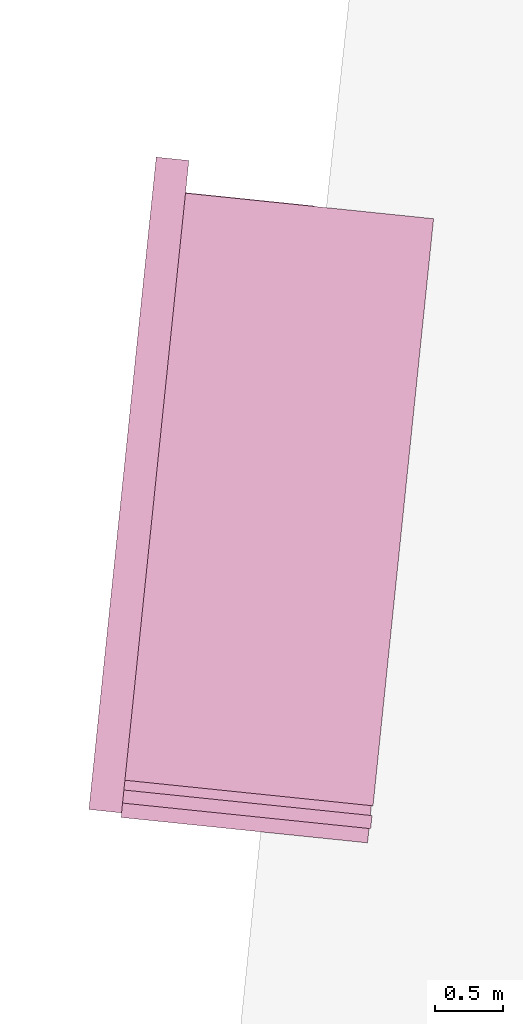
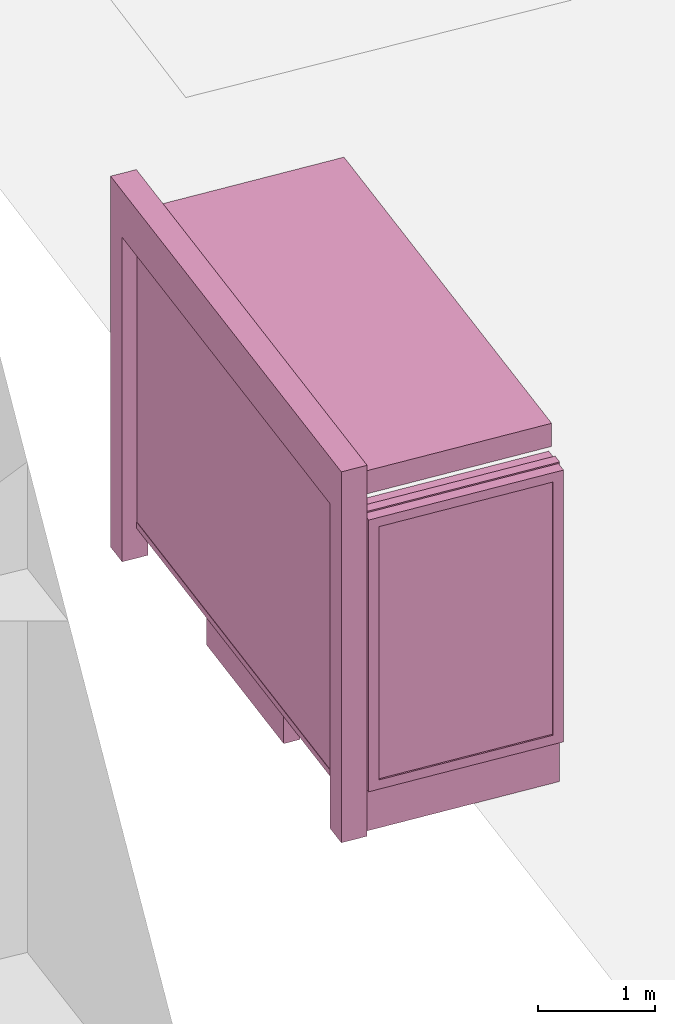
# One storey, part 28 of 200: 1 furnishing.
"""IFC4 building model written with IfcOpenShell, lengths in metres."""

from ifc_helpers import new_model, si_unit, origin_with_axes, place, context, subcontext, project, spatial, triangles, material, element, save


model = new_model("IFC4")

# Units and contexts
model_context = context("Model", 3, precision=1e-05, world=origin_with_axes())
body_context = subcontext(model_context, "Body", "Model", "MODEL_VIEW")
ifc_project = project(units=[si_unit("VOLUMEUNIT", "CUBIC_METRE"), si_unit("LENGTHUNIT", "METRE"), si_unit("AREAUNIT", "SQUARE_METRE")], contexts=[model_context])

# Site, building, storey
site_placement = place(None, origin_with_axes())
site = spatial("IfcSite", under=ifc_project, at=site_placement)
building_placement = place(site_placement, origin_with_axes())
building = spatial("IfcBuilding", under=site, at=building_placement, Name="Building")
storey_placement = place(building_placement, origin_with_axes())
storey = spatial("IfcBuildingStorey", under=building, at=storey_placement, Name="Ground")

# Furnishing
ifc_material = material(Name="busStop")
furnishing_placement = place(storey_placement, origin_with_axes())
element("IfcFurnishingElement", 1, at=furnishing_placement, inside=storey, material=ifc_material, Name="cw_instances_busStop_32", context=body_context, shape_type="Tessellation", body=[
    triangles([(364.8300022669944, -634.9630978992647, 3.3826375611235573), (363.211764228996, -630.4343599842039, 3.3826375611235573), (362.7664539243932, -634.7501776838506, 3.3826375611235573), (365.27531279753816, -630.6472800452291, 3.3826375611235573), (364.8300023629015, -634.9630979091604, 3.6236783199298275), (363.2117643249031, -630.4343599940996, 3.6236783199298275), (365.27531289344523, -630.6472800551248, 3.6236783199298275), (362.7664540203003, -634.7501776937463, 3.6236783199298275), (364.8300022669944, -634.9630978992647, 3.3826375611235573), (365.27531289344523, -630.6472800551248, 3.6236783199298275), (365.27531279753816, -630.6472800452291, 3.3826375611235573), (364.8300023629015, -634.9630979091604, 3.6236783199298275), (365.27531279753816, -630.6472800452291, 3.3826375611235573), (363.2117643249031, -630.4343599940996, 3.6236783199298275), (363.211764228996, -630.4343599842039, 3.3826375611235573), (365.27531289344523, -630.6472800551248, 3.6236783199298275), (363.211764228996, -630.4343599842039, 3.3826375611235573), (362.7664540203003, -634.7501776937463, 3.6236783199298275), (362.7664539243932, -634.7501776838506, 3.3826375611235573), (363.2117643249031, -630.4343599940996, 3.6236783199298275), (362.7664539243932, -634.7501776838506, 3.3826375611235573), (364.8300023629015, -634.9630979091604, 3.6236783199298275), (364.8300022669944, -634.9630978992647, 3.3826375611235573), (362.7664540203003, -634.7501776937463, 3.6236783199298275), (363.00622201757756, -634.774917137996, 3.864718677001767), (362.7417149618365, -634.9899455531278, 3.864718677001767), (362.766454387944, -634.7501777316801, 3.864718677001767), (362.9814825914701, -635.0146849594437, 3.864718677001767), (363.00622201757756, -634.774917137996, 3.6236783199298275), (362.9814825914701, -635.0146849594437, 3.864718677001767), (363.00622201757756, -634.774917137996, 3.864718677001767), (362.9814825914701, -635.0146849594437, 3.6236783199298275), (363.4762719346457, -630.2193318461411, 3.6236783199298275), (363.236504113198, -630.1945924200336, 3.864718677001767), (363.236504113198, -630.1945924200336, 3.6236783199298275), (363.4762719346457, -630.2193318461411, 3.864718677001767), (363.21176470853135, -630.4343600336827, 3.6236783199298275), (363.236504113198, -630.1945924200336, 3.864718677001767), (363.21176470853135, -630.4343600336827, 3.864718677001767), (363.236504113198, -630.1945924200336, 3.6236783199298275), (362.7417147860069, -634.9899455349855, 3.6236783199298275), (362.9814825914701, -635.0146849594437, 3.864718677001767), (362.9814825914701, -635.0146849594437, 3.6236783199298275), (362.7417149618365, -634.9899455531278, 3.864718677001767), (363.4515323381649, -630.4590994399986, 3.864718677001767), (363.21176470853135, -630.4343600336827, 3.864718677001767), (363.4515323381649, -630.4590994399986, 3.6236783199298275), (363.4515323381649, -630.4590994399986, 3.864718677001767), (362.7417147860069, -634.9899455349855, 3.6236783199298275), (362.766454387944, -634.7501777316801, 3.864718677001767), (362.7417149618365, -634.9899455531278, 3.864718677001767), (362.766454387944, -634.7501777316801, 3.6236783199298275), (363.4762719346457, -630.2193318461411, 3.864718677001767), (363.236504113198, -630.1945924200336, 3.864718677001767), (363.4762719346457, -630.2193318461411, 3.6236783199298275), (363.4762719346457, -630.2193318461411, 3.864718677001767), (362.74171392284336, -634.9899454459237, 9.480930192426488e-07), (362.98148145656984, -635.0146848423439, 8.998848996201414e-07), (362.7664533489508, -634.7501776244759, 9.480930192426488e-07), (362.74171392284336, -634.9899454459237, 9.480930192426488e-07), (362.766454387944, -634.7501777316801, 3.6236783199298275), (363.0062210585069, -634.7749170390383, 8.998848996201414e-07), (363.00622201757756, -634.774917137996, 3.6236783199298275), (362.7664533489508, -634.7501776244759, 9.480930192426488e-07), (362.98148145656984, -635.0146848423439, 8.998848996201414e-07), (363.0062210585069, -634.7749170390383, 8.998848996201414e-07), (363.476270627078, -630.2193332459204, 8.998848996201414e-07), (363.2365030742048, -630.1945923128295, 9.480930192426488e-07), (363.45153122076204, -630.459100875554, 8.998848996201414e-07), (363.476270627078, -630.2193332459204, 8.998848996201414e-07), (363.4515323381649, -630.4590994399986, 3.6236783199298275), (363.2117635112059, -630.4343614609916, 9.480930192426488e-07), (363.21176470853135, -630.4343600336827, 3.6236783199298275), (363.45153122076204, -630.459100875554, 8.998848996201414e-07), (363.2365030742048, -630.1945923128295, 9.480930192426488e-07), (363.2117635112059, -630.4343614609916, 9.480930192426488e-07), (364.39789235899724, -630.5569974864676, 0.3459945917589383), (363.35714615340737, -630.4496125017171, 3.3826375611235573), (363.35714529024375, -630.4496124126551, 0.34599476852204364), (364.3978931422383, -630.556997567283, 3.3826375611235573), (363.35549599791875, -630.4655969074441, 0.34599476852204364), (364.3962438499133, -630.572982062072, 3.3826375611235573), (364.39624306667224, -630.5729819812566, 0.3459945917589383), (363.3554968610823, -630.4655969965061, 3.3826375611235573), (364.39624306667224, -630.5729819812566, 0.3459945917589383), (364.3978931422383, -630.556997567283, 3.3826375611235573), (364.39789235899724, -630.5569974864676, 0.3459945917589383), (364.3962438499133, -630.572982062072, 3.3826375611235573), (363.3550836645294, -630.4695931310446, 0.313856054245785), (364.3983046246415, -630.5530014497334, 0.3138558614133065), (363.3575576038416, -630.4456163808688, 0.313856054245785), (364.3958306853294, -630.5769781999091, 0.3138558614133065), (363.3550836645294, -630.4695931310446, 0.37813349886767544), (364.39830464062607, -630.5530014513827, 0.37813330603519696), (364.39583070131386, -630.5769782015584, 0.37813330603519696), (363.3575576038416, -630.4456163808688, 0.37813349886767544), (363.3550836645294, -630.4695931310446, 0.313856054245785), (364.39583070131386, -630.5769782015584, 0.37813330603519696), (364.3958306853294, -630.5769781999091, 0.3138558614133065), (363.3550836645294, -630.4695931310446, 0.37813349886767544), (364.3983046246415, -630.5530014497334, 0.3138558614133065), (363.3575576038416, -630.4456163808688, 0.37813349886767544), (363.3575576038416, -630.4456163808688, 0.313856054245785), (364.39830464062607, -630.5530014513827, 0.37813330603519696), (364.39830464062607, -630.5530014513827, 0.37813330603519696), (364.3958306853294, -630.5769781999091, 0.3138558614133065), (364.39583070131386, -630.5769782015584, 0.37813330603519696), (364.3983046246415, -630.5530014497334, 0.3138558614133065), (364.41822449195774, -630.5755377563904, 0.37813330603519696), (364.3759108013838, -630.5544436200877, 0.37813330603519696), (364.41993233586817, -630.5589857954844, 0.37813330603519696), (364.3742029574734, -630.5709955809937, 0.37813330603519696), (364.4182242362056, -630.5755377300018, 1.446243588675227e-07), (364.41993233586817, -630.5589857954844, 0.37813330603519696), (364.419932080116, -630.5589857690958, 1.446243588675227e-07), (364.41822449195774, -630.5755377563904, 0.37813330603519696), (364.419932080116, -630.5589857690958, 1.446243588675227e-07), (364.3759108013838, -630.5544436200877, 0.37813330603519696), (364.37591068949223, -630.5544436085427, 1.6069373207502523e-07), (364.41993233586817, -630.5589857954844, 0.37813330603519696), (364.37591068949223, -630.5544436085427, 1.6069373207502523e-07), (364.3742029574734, -630.5709955809937, 0.37813330603519696), (364.3742028455818, -630.5709955694487, 1.6069373207502523e-07), (364.3759108013838, -630.5544436200877, 0.37813330603519696), (364.3742028455818, -630.5709955694487, 1.6069373207502523e-07), (364.41822449195774, -630.5755377563904, 0.37813330603519696), (364.4182242362056, -630.5755377300018, 1.446243588675227e-07), (364.3742029574734, -630.5709955809937, 0.37813330603519696), (363.20580706503574, -633.4820034093999, 1.1248564780513874), (363.2181104553161, -631.8678042645932, 1.1248565744676267), (363.3707369420013, -631.8835523815281, 1.1248564780513874), (363.05318077016466, -633.4662553122565, 1.1248565744676267), (363.37073675018723, -631.8835523617366, 4.981505694325782e-07), (363.20580706503574, -633.4820034093999, 0.964162810253855), (363.3707369420013, -631.8835523815281, 0.964162810253855), (363.20580672936103, -633.4820033747648, 4.981505694325782e-07), (363.2181100716879, -631.8678042250102, 5.302893158475833e-07), (363.3707369420013, -631.8835523815281, 0.964162810253855), (363.2181104553161, -631.8678042645932, 0.9641629066700942), (363.37073675018723, -631.8835523617366, 4.981505694325782e-07), (363.0531803865364, -633.4662552726735, 5.302893158475833e-07), (363.2181104553161, -631.8678042645932, 0.9641629066700942), (363.05318077016466, -633.4662553122565, 0.9641629066700942), (363.2181100716879, -631.8678042250102, 5.302893158475833e-07), (363.20580672936103, -633.4820033747648, 4.981505694325782e-07), (363.05318077016466, -633.4662553122565, 0.9641629066700942), (363.20580706503574, -633.4820034093999, 0.964162810253855), (363.0531803865364, -633.4662552726735, 5.302893158475833e-07), (364.01011730900353, -631.9495241339031, 1.124856381635148), (363.8451875119605, -633.5479751700213, 0.9641627138376155), (363.8451875439295, -633.54797517332, 1.124856381635148), (364.01011729301905, -631.9495241322538, 0.9641627138376155), (363.2181104553161, -631.8678042645932, 1.1248565744676267), (363.3707369420013, -631.8835523815281, 1.1248564780513874), (363.05318077016466, -633.4662553122565, 1.1248565744676267), (363.2181104553161, -631.8678042645932, 1.1248565744676267), (363.20580706503574, -633.4820034093999, 1.1248564780513874), (363.05318077016466, -633.4662553122565, 1.1248565744676267), (363.8451875439295, -633.54797517332, 1.124856381635148), (364.01011730900353, -631.9495241339031, 1.124856381635148), (363.8451875119605, -633.5479751700213, 0.9641627138376155), (363.8451875439295, -633.54797517332, 1.124856381635148), (364.01011730900353, -631.9495241339031, 1.124856381635148), (364.01011729301905, -631.9495241322538, 0.9641627138376155), (362.90551733673675, -634.9049413823512, 0.34599476852204364), (363.37753391756206, -630.3303040157349, 3.503157940526693), (363.3775329744759, -630.3303039184265, 0.34599476852204364), (362.90551800808623, -634.9049414516217, 3.503157940526693), (363.3615484637024, -630.3286546244522, 0.34599476852204364), (362.88953351329724, -634.9032921592966, 3.503157940526693), (362.88953284194776, -634.9032920900263, 0.34599476852204364), (363.36154942277307, -630.3286547234098, 3.503157940526693), (363.0755643412994, -635.0422610035295, 0.5810001600002933), (364.6953380846724, -635.2093904898511, 3.2193552137185355), (364.69533750923006, -635.2093904304764, 0.5809998707515756), (363.07556494871085, -635.0422610662026, 3.2193552137185355), (362.9780079843334, -635.0483497344726, 0.4845839046859049), (364.69368821690506, -635.2253749252654, 0.5809998707515756), (364.78959502895606, -635.235272197744, 0.48458358329844076), (363.0739150489744, -635.0582454983185, 0.5810001600002933), (364.6936887923474, -635.2253749846401, 3.2193552137185355), (364.7895960488026, -635.2352707682775, 3.3157713565473115), (363.07391565638585, -635.0582455609916, 3.2193552137185355), (362.9780086396983, -635.0483498020936, 3.3157713565473115), (363.0739150489744, -635.0582454983185, 0.5810001600002933), (364.69533750923006, -635.2093904304764, 0.5809998707515756), (364.69368821690506, -635.2253749252654, 0.5809998707515756), (363.0755643412994, -635.0422610035295, 0.5810001600002933), (364.69368821690506, -635.2253749252654, 0.5809998707515756), (364.6953380846724, -635.2093904898511, 3.2193552137185355), (364.6936887923474, -635.2253749846401, 3.2193552137185355), (364.69533750923006, -635.2093904304764, 0.5809998707515756), (364.6936887923474, -635.2253749846401, 3.2193552137185355), (363.07556494871085, -635.0422610662026, 3.2193552137185355), (363.07391565638585, -635.0582455609916, 3.2193552137185355), (364.6953380846724, -635.2093904898511, 3.2193552137185355), (363.07391565638585, -635.0582455609916, 3.2193552137185355), (363.0755643412994, -635.0422610035295, 0.5810001600002933), (363.0739150489744, -635.0582454983185, 0.5810001600002933), (363.07556494871085, -635.0422610662026, 3.2193552137185355), (364.8212826111971, -634.9281731823637, 3.3157713565473115), (362.9780086396983, -635.0483498020936, 3.3157713565473115), (363.009695489814, -634.7412522458673, 3.3157713565473115), (364.7895960488026, -635.2352707682775, 3.3157713565473115), (364.8212817480335, -634.9281730933018, 0.48458358329844076), (364.7895960488026, -635.2352707682775, 3.3157713565473115), (364.8212826111971, -634.9281731823637, 3.3157713565473115), (364.78959502895606, -635.235272197744, 0.48458358329844076), (362.9780079843334, -635.0483497344726, 0.4845839046859049), (363.009695489814, -634.7412522458673, 3.3157713565473115), (362.9780086396983, -635.0483498020936, 3.3157713565473115), (363.0096947225575, -634.7412521667011, 0.4845839046859049), (363.10395246290454, -634.7671324220373, 0.5810001600002933), (364.7237260624169, -634.9342618935153, 3.2193552137185355), (363.10395326213006, -634.767132504502, 3.2193552137185355), (364.72372548697456, -634.9342618341408, 0.5809998707515756), (363.0096947225575, -634.7412521667011, 0.4845839046859049), (364.72537477929956, -634.9182773393518, 0.5809998707515756), (363.10560175522954, -634.7511479272483, 0.5810001600002933), (364.8212817480335, -634.9281730933018, 0.48458358329844076), (364.7253753547419, -634.9182773987263, 3.2193552137185355), (364.8212826111971, -634.9281731823637, 3.3157713565473115), (363.10560255445506, -634.751148009713, 3.2193552137185355), (363.009695489814, -634.7412522458673, 3.3157713565473115), (363.10560175522954, -634.7511479272483, 0.5810001600002933), (364.72372548697456, -634.9342618341408, 0.5809998707515756), (363.10395246290454, -634.7671324220373, 0.5810001600002933), (364.72537477929956, -634.9182773393518, 0.5809998707515756), (364.72537477929956, -634.9182773393518, 0.5809998707515756), (364.7237260624169, -634.9342618935153, 3.2193552137185355), (364.72372548697456, -634.9342618341408, 0.5809998707515756), (364.7253753547419, -634.9182773987263, 3.2193552137185355), (364.7253753547419, -634.9182773987263, 3.2193552137185355), (363.10395326213006, -634.767132504502, 3.2193552137185355), (364.7237260624169, -634.9342618935153, 3.2193552137185355), (363.10560255445506, -634.751148009713, 3.2193552137185355), (363.10560255445506, -634.751148009713, 3.2193552137185355), (363.10395246290454, -634.7671324220373, 0.5810001600002933), (363.10395326213006, -634.767132504502, 3.2193552137185355), (363.10560175522954, -634.7511479272483, 0.5810001600002933), (364.81268485344015, -635.1309335840128, 3.3287619342644956), (362.9987997978706, -634.8468475247698, 3.3287619342644956), (364.8225804507073, -635.0350281338074, 3.3287619342644956), (362.98890404392057, -634.9427544935038, 3.3287619342644956), (364.81268400561623, -635.1309352250851, 0.0), (364.8225804507073, -635.0350281338074, 3.3287619342644956), (364.8225797793578, -635.035028064537, 0.0), (364.81268485344015, -635.1309335840128, 3.3287619342644956), (364.8225797793578, -635.035028064537, 0.0), (362.9987997978706, -634.8468475247698, 3.3287619342644956), (362.9987990465986, -634.846847447253, 5.142199426400808e-07), (364.8225804507073, -635.0350281338074, 3.3287619342644956), (362.9987990465986, -634.846847447253, 5.142199426400808e-07), (362.98890404392057, -634.9427544935038, 3.3287619342644956), (362.98890329264856, -634.942754415987, 5.142199426400808e-07), (362.9987997978706, -634.8468475247698, 3.3287619342644956), (362.98890329264856, -634.942754415987, 5.142199426400808e-07), (364.81268485344015, -635.1309335840128, 3.3287619342644956), (364.81268400561623, -635.1309352250851, 0.0), (362.98890404392057, -634.9427544935038, 3.3287619342644956), (362.9095134644301, -634.9053537058448, 0.313856054245785), (363.34733999767485, -630.4272167370171, 0.313856054245785), (362.8855366183473, -634.9028797566369, 0.313856054245785), (363.3713167318661, -630.4296906746799, 0.313856054245785), (362.9095134644301, -634.9053537058448, 0.37813349886767544), (363.34733999767485, -630.4272167370171, 0.37813349886767544), (363.3713167318661, -630.4296906746799, 0.37813349886767544), (362.8855366183473, -634.9028797566369, 0.37813349886767544), (362.9095134644301, -634.9053537058448, 0.313856054245785), (363.3713167318661, -630.4296906746799, 0.37813349886767544), (363.3713167318661, -630.4296906746799, 0.313856054245785), (362.9095134644301, -634.9053537058448, 0.37813349886767544), (363.34733999767485, -630.4272167370171, 0.313856054245785), (362.8855366183473, -634.9028797566369, 0.37813349886767544), (362.8855366183473, -634.9028797566369, 0.313856054245785), (363.34733999767485, -630.4272167370171, 0.37813349886767544), (363.07057915404573, -633.3065031442954, 1.5290613779533648), (363.20252334498866, -632.0277423357009, 2.8146110577904615), (363.07057953767395, -633.3065031838785, 2.8146110577904615), (363.20252296136044, -632.0277422961177, 1.5290613779533648), (363.0873137319729, -633.2759204422549, 1.5612002850621018), (363.21266072773557, -632.0610977070739, 2.7824723435142027), (363.2126601682777, -632.0610976493487, 1.5612002850621018), (363.08731392378706, -633.2759204620464, 2.7824723435142027), (363.07057915404573, -633.3065031442954, 1.5290613779533648), (363.23194344447876, -632.0307779239337, 1.5290613779533648), (363.20252296136044, -632.0277422961177, 1.5290613779533648), (363.0999994453499, -633.3095387523199, 1.5290613779533648), (363.20252296136044, -632.0277422961177, 1.5290613779533648), (363.23194362030836, -632.0307779420759, 2.8146110577904615), (363.20252334498866, -632.0277423357009, 2.8146110577904615), (363.23194344447876, -632.0307779239337, 1.5290613779533648), (363.20252334498866, -632.0277423357009, 2.8146110577904615), (363.0999998289781, -633.3095387919029, 2.8146110577904615), (363.07057953767395, -633.3065031838785, 2.8146110577904615), (363.23194362030836, -632.0307779420759, 2.8146110577904615), (363.07057953767395, -633.3065031838785, 2.8146110577904615), (363.0999994453499, -633.3095387523199, 1.5290613779533648), (363.07057915404573, -633.3065031442954, 1.5290613779533648), (363.0999998289781, -633.3095387919029, 2.8146110577904615), (363.24104097031613, -631.6544361792462, 1.5290613779533648), (363.32350644618356, -630.85521062383, 2.8146110577904615), (363.2410415556543, -631.6544361427137, 2.8146110577904615), (363.3235060625553, -630.855210584247, 1.5290613779533648), (363.2577753712729, -631.6238533135535, 1.5612002850621018), (363.33364354615713, -630.8885659175622, 2.7824723435142027), (363.333643258436, -630.888565887875, 1.5612002850621018), (363.25777593073076, -631.6238533712788, 2.7824723435142027), (363.24104097031613, -631.6544361792462, 1.5290613779533648), (363.352926337875, -630.858246190622, 1.5290613779533648), (363.3235060625553, -630.855210584247, 1.5290613779533648), (363.27046145343445, -631.6574718070622, 1.5290613779533648), (363.3235060625553, -630.855210584247, 1.5290613779533648), (363.35292672150325, -630.858246230205, 2.8146110577904615), (363.32350644618356, -630.85521062383, 2.8146110577904615), (363.352926337875, -630.858246190622, 1.5290613779533648), (363.32350644618356, -630.85521062383, 2.8146110577904615), (363.27046183097394, -631.6574717490888, 2.8146110577904615), (363.2410415556543, -631.6544361427137, 2.8146110577904615), (363.35292672150325, -630.858246230205, 2.8146110577904615), (363.2410415556543, -631.6544361427137, 2.8146110577904615), (363.27046145343445, -631.6574718070622, 1.5290613779533648), (363.24104097031613, -631.6544361792462, 1.5290613779533648), (363.27046183097394, -631.6574717490888, 2.8146110577904615), (363.0999994453499, -633.3095387523199, 1.5290613779533648), (363.22864475897376, -632.0627469515695, 1.5612002850621018), (363.23194344447876, -632.0307779239337, 1.5290613779533648), (363.1032980349478, -633.2775697147883, 1.5612002850621018), (363.2286450307104, -632.0627469796075, 2.7824723435142027), (363.23194362030836, -632.0307779420759, 2.8146110577904615), (363.10329841857606, -633.2775697543714, 2.7824723435142027), (363.0999998289781, -633.3095387919029, 2.8146110577904615), (363.27046145343445, -631.6574718070622, 1.5290613779533648), (363.349627753225, -630.8902151802, 1.5612002850621018), (363.352926337875, -630.858246190622, 1.5290613779533648), (363.273760057876, -631.62550262567, 1.5612002850621018), (363.3496281368532, -630.890215219783, 2.7824723435142027), (363.35292672150325, -630.858246230205, 2.8146110577904615), (363.27376042551975, -631.6255026636038, 2.7824723435142027), (363.27046183097394, -631.6574717490888, 2.8146110577904615), (363.1032980349478, -633.2775697147883, 1.5612002850621018), (363.2126601682777, -632.0610976493487, 1.5612002850621018), (363.22864475897376, -632.0627469515695, 1.5612002850621018), (363.0873137319729, -633.2759204422549, 1.5612002850621018), (363.22864475897376, -632.0627469515695, 1.5612002850621018), (363.21266072773557, -632.0610977070739, 2.7824723435142027), (363.2286450307104, -632.0627469796075, 2.7824723435142027), (363.2126601682777, -632.0610976493487, 1.5612002850621018), (363.2286450307104, -632.0627469796075, 2.7824723435142027), (363.08731392378706, -633.2759204620464, 2.7824723435142027), (363.10329841857606, -633.2775697543714, 2.7824723435142027), (363.21266072773557, -632.0610977070739, 2.7824723435142027), (363.10329841857606, -633.2775697543714, 2.7824723435142027), (363.0873137319729, -633.2759204422549, 1.5612002850621018), (363.1032980349478, -633.2775697147883, 1.5612002850621018), (363.08731392378706, -633.2759204620464, 2.7824723435142027), (363.273760057876, -631.62550262567, 1.5612002850621018), (363.333643258436, -630.888565887875, 1.5612002850621018), (363.349627753225, -630.8902151802, 1.5612002850621018), (363.2577753712729, -631.6238533135535, 1.5612002850621018), (363.349627753225, -630.8902151802, 1.5612002850621018), (363.33364354615713, -630.8885659175622, 2.7824723435142027), (363.3496281368532, -630.890215219783, 2.7824723435142027), (363.333643258436, -630.888565887875, 1.5612002850621018), (363.3496281368532, -630.890215219783, 2.7824723435142027), (363.25777593073076, -631.6238533712788, 2.7824723435142027), (363.27376042551975, -631.6255026636038, 2.7824723435142027), (363.33364354615713, -630.8885659175622, 2.7824723435142027), (363.27376042551975, -631.6255026636038, 2.7824723435142027), (363.2577753712729, -631.6238533135535, 1.5612002850621018), (363.273760057876, -631.62550262567, 1.5612002850621018), (363.25777593073076, -631.6238533712788, 2.7824723435142027)], [[1, 3, 2], [2, 4, 1], [5, 7, 6], [6, 8, 5], [9, 11, 10], [10, 12, 9], [13, 15, 14], [14, 16, 13], [17, 19, 18], [18, 20, 17], [21, 23, 22], [22, 24, 21], [25, 27, 26], [26, 28, 25], [29, 31, 30], [30, 32, 29], [33, 35, 34], [34, 36, 33], [37, 39, 38], [38, 40, 37], [41, 43, 42], [42, 44, 41], [45, 46, 27], [27, 25, 45], [47, 48, 31], [31, 29, 47], [49, 51, 50], [50, 52, 49], [52, 50, 39], [39, 37, 52], [53, 54, 46], [46, 45, 53], [55, 56, 48], [48, 47, 55], [43, 41, 57], [57, 58, 43], [49, 52, 59], [59, 60, 49], [61, 63, 62], [62, 64, 61], [29, 32, 65], [65, 66, 29], [35, 33, 67], [67, 68, 35], [55, 47, 69], [69, 70, 55], [71, 73, 72], [72, 74, 71], [37, 40, 75], [75, 76, 37], [77, 79, 78], [78, 80, 77], [81, 83, 82], [82, 84, 81], [85, 87, 86], [86, 88, 85], [89, 91, 90], [90, 92, 89], [93, 95, 94], [94, 96, 93], [97, 99, 98], [98, 100, 97], [101, 103, 102], [102, 104, 101], [105, 107, 106], [106, 108, 105], [109, 111, 110], [110, 112, 109], [113, 115, 114], [114, 116, 113], [117, 119, 118], [118, 120, 117], [121, 123, 122], [122, 124, 121], [125, 127, 126], [126, 128, 125], [129, 131, 130], [130, 132, 129], [133, 135, 134], [134, 136, 133], [137, 139, 138], [138, 140, 137], [141, 143, 142], [142, 144, 141], [145, 147, 146], [146, 148, 145], [149, 151, 150], [150, 152, 149], [153, 154, 138], [138, 139, 153], [155, 156, 142], [142, 143, 155], [157, 158, 146], [146, 147, 157], [131, 129, 159], [159, 160, 131], [157, 147, 161], [161, 162, 157], [138, 154, 163], [163, 164, 138], [165, 167, 166], [166, 168, 165], [169, 171, 170], [170, 172, 169], [173, 175, 174], [174, 176, 173], [177, 179, 178], [178, 180, 177], [179, 182, 181], [181, 178, 179], [182, 184, 183], [183, 181, 182], [184, 177, 180], [180, 183, 184], [185, 187, 186], [186, 188, 185], [189, 191, 190], [190, 192, 189], [193, 195, 194], [194, 196, 193], [197, 199, 198], [198, 200, 197], [201, 203, 202], [202, 204, 201], [205, 207, 206], [206, 208, 205], [209, 211, 210], [210, 212, 209], [213, 215, 214], [214, 216, 213], [217, 219, 218], [218, 220, 217], [220, 218, 221], [221, 222, 220], [222, 221, 223], [223, 224, 222], [224, 223, 219], [219, 217, 224], [225, 227, 226], [226, 228, 225], [229, 231, 230], [230, 232, 229], [233, 235, 234], [234, 236, 233], [237, 239, 238], [238, 240, 237], [241, 243, 242], [242, 244, 241], [245, 247, 246], [246, 248, 245], [249, 251, 250], [250, 252, 249], [253, 255, 254], [254, 256, 253], [257, 259, 258], [258, 260, 257], [261, 263, 262], [262, 264, 261], [265, 267, 266], [266, 268, 265], [269, 271, 270], [270, 272, 269], [273, 275, 274], [274, 276, 273], [277, 279, 278], [278, 280, 277], [281, 283, 282], [282, 284, 281], [285, 287, 286], [286, 288, 285], [289, 291, 290], [290, 292, 289], [293, 295, 294], [294, 296, 293], [297, 299, 298], [298, 300, 297], [301, 303, 302], [302, 304, 301], [305, 307, 306], [306, 308, 305], [309, 311, 310], [310, 312, 309], [313, 315, 314], [314, 316, 313], [317, 319, 318], [318, 320, 317], [321, 323, 322], [322, 324, 321], [325, 327, 326], [326, 328, 325], [327, 330, 329], [329, 326, 327], [330, 332, 331], [331, 329, 330], [332, 325, 328], [328, 331, 332], [333, 335, 334], [334, 336, 333], [335, 338, 337], [337, 334, 335], [338, 340, 339], [339, 337, 338], [340, 333, 336], [336, 339, 340], [341, 343, 342], [342, 344, 341], [345, 347, 346], [346, 348, 345], [349, 351, 350], [350, 352, 349], [353, 355, 354], [354, 356, 353], [357, 359, 358], [358, 360, 357], [361, 363, 362], [362, 364, 361], [365, 367, 366], [366, 368, 365], [369, 371, 370], [370, 372, 369]], closed=True),
])

save(model, "model.ifc")
